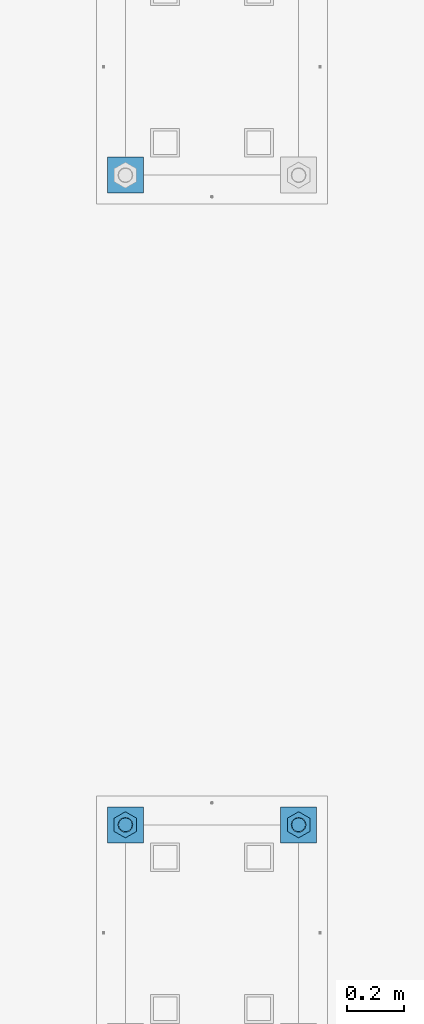
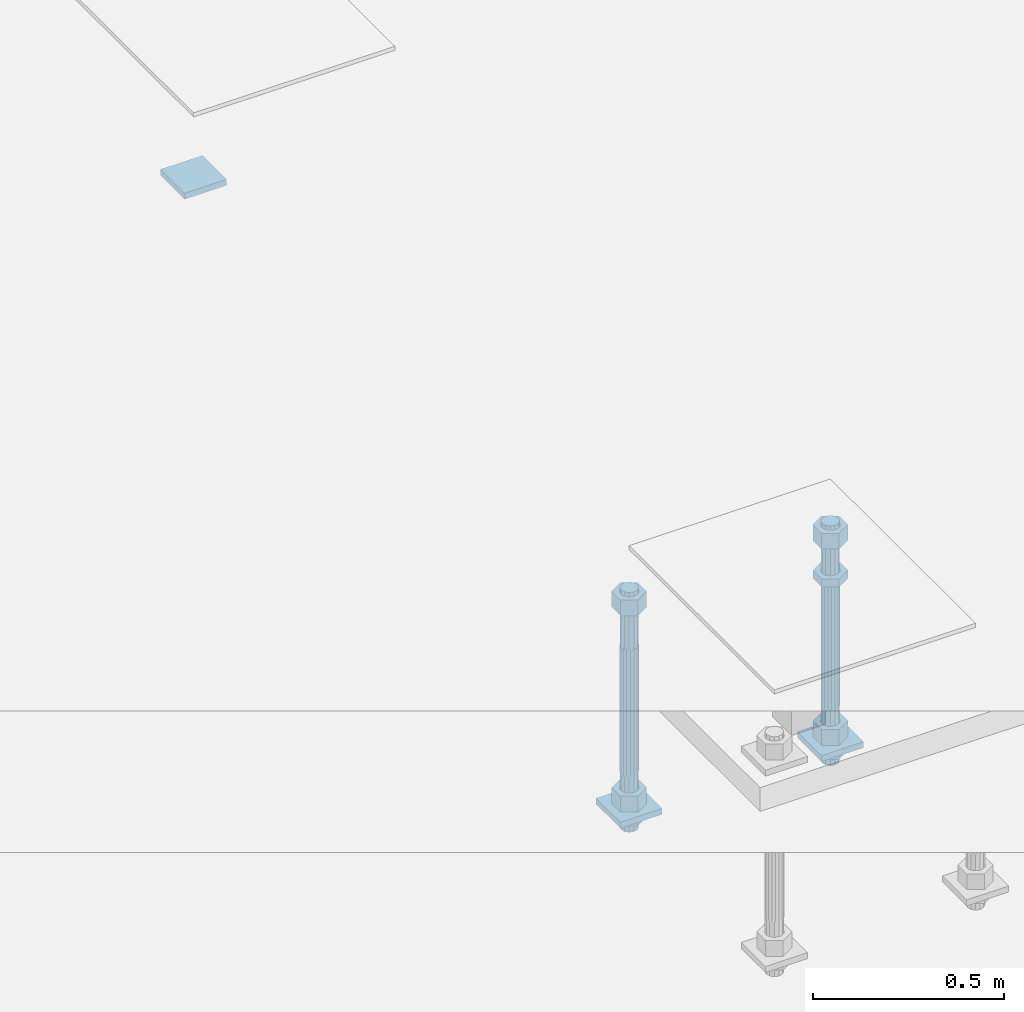
# One storey, part 2641 of 3843: 12 beams, 2 elements without a shape of their own.
"""IFC2X3 building model written with IfcOpenShell, lengths in millimetres."""

from ifc_helpers import new_model, si_unit, frame, origin_with_axes, place, context, subcontext, project, spatial, faceted_brep, material, type_object, element, aggregate, save


model = new_model("IFC2X3")

# Units and contexts
model_context = context("Model", 3, precision=1e-05, world=origin_with_axes())
body_context = subcontext(model_context, "Body", "Model", "MODEL_VIEW")
ifc_project = project(units=[si_unit("LENGTHUNIT", "METRE", prefix="MILLI"), si_unit("AREAUNIT", "SQUARE_METRE"), si_unit("VOLUMEUNIT", "CUBIC_METRE"), si_unit("MASSUNIT", "GRAM", prefix="KILO"), si_unit("TIMEUNIT", "SECOND"), si_unit("PLANEANGLEUNIT", "RADIAN"), si_unit("SOLIDANGLEUNIT", "STERADIAN"), si_unit("THERMODYNAMICTEMPERATUREUNIT", "DEGREE_CELSIUS"), si_unit("LUMINOUSINTENSITYUNIT", "LUMEN")], contexts=[model_context])

# Site, building, storey
site_placement = place(None, origin_with_axes())
site = spatial("IfcSite", under=ifc_project, at=site_placement, CompositionType="ELEMENT")
building_placement = place(site_placement, origin_with_axes())
building = spatial("IfcBuilding", under=site, at=building_placement, Name="Undefined", CompositionType="ELEMENT")
storey_placement = place(building_placement, origin_with_axes())
storey = spatial("IfcBuildingStorey", under=building, at=storey_placement, Name="Undefined", CompositionType="ELEMENT", Elevation=0.0)

# Assembly, beam
assembly_1_placement = place(storey_placement, origin_with_axes())
assembly_1 = element("IfcElementAssembly", 1, at=assembly_1_placement, inside=storey, Name="TEMPLATE", AssemblyPlace="NOTDEFINED", PredefinedType="RIGID_FRAME")
ifc_material_1 = material(Name="STEEL/A36")
beam_type_1 = type_object("IfcBeamType", PredefinedType="NOTDEFINED")
beam_1_placement = place(assembly_1_placement, frame((115862.099998474, 10121.9, 29873.575), z_axis=(0.0, 1.0, 0.0), x_axis=(-1.0, 0.0, 0.0)))
beam_1 = element("IfcBeam", 2, at=beam_1_placement, type_object=beam_type_1, material=ifc_material_1, Name="WASHER_PLATE", context=body_context, shape_type="Brep", body=[
    faceted_brep([(0.0, 9.52500000000146, -63.5), (0.0, 9.52500000000146, 63.5), (127.0, 9.52500000000146, 63.5), (127.0, 9.52500000000146, -63.5), (0.0, -9.52500000000146, 63.5), (127.0, -9.52500000000146, 63.5), (0.0, -9.52500000000146, -63.5), (127.0, -9.52500000000146, -63.5)], [[[0, 1, 2, 3]], [[1, 4, 5, 2]], [[4, 6, 7, 5]], [[6, 0, 3, 7]], [[5, 7, 3, 2]], [[6, 4, 1, 0]]]),
])
aggregate(assembly_1, [beam_1])

# Assembly, beams
assembly_2_placement = place(storey_placement, origin_with_axes())
assembly_2 = element("IfcElementAssembly", 3, at=assembly_2_placement, inside=storey, Name="TEMPLATE", AssemblyPlace="NOTDEFINED", PredefinedType="RIGID_FRAME")
beam_2_placement = place(assembly_2_placement, frame((116471.7, 7835.90000000001, 29244.925), z_axis=(0.0, 1.0, 0.0), x_axis=(-1.0, 0.0, 0.0)))
beam_2 = element("IfcBeam", 4, at=beam_2_placement, type_object=beam_type_1, material=ifc_material_1, Name="WASHER_PLATE", context=body_context, shape_type="Brep", body=[
    faceted_brep([(0.0, 9.52500000000146, -63.5), (0.0, 9.52500000000146, 63.5), (127.0, 9.52500000000146, 63.5), (127.0, 9.52500000000146, -63.5), (0.0, -9.52500000000146, 63.5), (127.0, -9.52500000000146, 63.5), (0.0, -9.52500000000146, -63.5), (127.0, -9.52500000000146, -63.5)], [[[0, 1, 2, 3]], [[1, 4, 5, 2]], [[4, 6, 7, 5]], [[6, 0, 3, 7]], [[5, 7, 3, 2]], [[6, 4, 1, 0]]]),
])
beam_3_placement = place(assembly_2_placement, frame((115862.099998474, 7835.90000000001, 29244.925), z_axis=(0.0, 1.0, 0.0), x_axis=(-1.0, 0.0, 0.0)))
beam_3 = element("IfcBeam", 5, at=beam_3_placement, type_object=beam_type_1, material=ifc_material_1, Name="WASHER_PLATE", context=body_context, shape_type="Brep", body=[
    faceted_brep([(0.0, 9.52500000000146, -63.5), (0.0, 9.52500000000146, 63.5), (127.0, 9.52500000000146, 63.5), (127.0, 9.52500000000146, -63.5), (0.0, -9.52500000000146, 63.5), (127.0, -9.52500000000146, 63.5), (0.0, -9.52500000000146, -63.5), (127.0, -9.52500000000146, -63.5)], [[[0, 1, 2, 3]], [[1, 4, 5, 2]], [[4, 6, 7, 5]], [[6, 0, 3, 7]], [[5, 7, 3, 2]], [[6, 4, 1, 0]]]),
])
beam_type_2 = type_object("IfcBeamType", Name="2_HALF_NUT", PredefinedType="NOTDEFINED")
beam_4_placement = place(assembly_2_placement, frame((115798.599998474, 7835.9, 29235.4), z_axis=(-1.0, 0.0, 0.0), x_axis=(0.0, 0.0, -1.0)))
beam_4 = element("IfcBeam", 6, at=beam_4_placement, type_object=beam_type_2, material=ifc_material_1, Name="NUT", ObjectType="2_HALF_NUT", context=body_context, shape_type="Brep", body=[
    faceted_brep([(0.0, -46.0369987487793, 0.0), (0.0, -23.0184993743896, -39.869213104248), (25.4000000000015, -23.0184993743896, -39.869213104248), (25.4000000000015, -46.0369987487793, 0.0), (0.0, 23.0184993743896, -39.869213104248), (25.4000000000015, 23.0184993743896, -39.869213104248), (0.0, 46.0369987487793, 0.0), (25.4000000000015, 46.0369987487793, 0.0), (0.0, 23.0184993743896, 39.869213104248), (25.4000000000015, 23.0184993743896, 39.869213104248), (0.0, -23.0184993743896, 39.869213104248), (25.4000000000015, -23.0184993743896, 39.869213104248), (0.0, 0.0, 26.1940002441406), (0.0, 11.3650617044477, 23.5999013092805), (25.4000000000015, 11.3650617044477, 23.5999013092805), (25.4000000000015, 0.0, 26.1940002441406), (0.0, 20.4791109456419, 16.3316083006721), (25.4000000000015, 20.4791109456419, 16.3316083006721), (0.0, 25.5370200498292, 5.82867859874386), (25.4000000000015, 25.5370200498292, 5.82867859874386), (0.0, 25.5370200498292, -5.82867859874386), (25.4000000000015, 25.5370200498292, -5.82867859874386), (0.0, 20.4791109456419, -16.3316083006721), (25.4000000000015, 20.4791109456419, -16.3316083006721), (0.0, 11.3650617044477, -23.5999013092805), (25.4000000000015, 11.3650617044477, -23.5999013092805), (0.0, 0.0, -26.1940002441406), (25.4000000000015, 0.0, -26.1940002441406), (0.0, -11.3650617044477, -23.5999013092805), (25.4000000000015, -11.3650617044477, -23.5999013092805), (0.0, -20.4791109456419, -16.3316083006721), (25.4000000000015, -20.4791109456419, -16.3316083006721), (0.0, -25.5370200498292, -5.82867859874386), (25.4000000000015, -25.5370200498292, -5.82867859874386), (0.0, -25.5370200498292, 5.82867859874386), (25.4000000000015, -25.5370200498292, 5.82867859874386), (0.0, -20.4791109456419, 16.3316083006721), (25.4000000000015, -20.4791109456419, 16.3316083006721), (0.0, -11.3650617044477, 23.5999013092805), (25.4000000000015, -11.3650617044477, 23.5999013092805)], [[[0, 1, 2, 3]], [[1, 4, 5, 2]], [[4, 6, 7, 5]], [[6, 8, 9, 7]], [[8, 10, 11, 9]], [[10, 0, 3, 11]], [[12, 13, 14, 15]], [[13, 16, 17, 14]], [[16, 18, 19, 17]], [[18, 20, 21, 19]], [[20, 22, 23, 21]], [[22, 24, 25, 23]], [[24, 26, 27, 25]], [[26, 28, 29, 27]], [[28, 30, 31, 29]], [[30, 32, 33, 31]], [[32, 34, 35, 33]], [[34, 36, 37, 35]], [[36, 38, 39, 37]], [[38, 12, 15, 39]], [[5, 7, 9, 11, 3, 2], [17, 19, 21, 23, 25, 27, 29, 31, 33, 35, 37, 39, 15, 14]], [[10, 8, 6, 4, 1, 0], [38, 36, 34, 32, 30, 28, 26, 24, 22, 20, 18, 16, 13, 12]]]),
])
beam_5_placement = place(assembly_2_placement, frame((116408.2, 7835.90000000001, 29787.85), z_axis=(-1.0, 0.0, 0.0), x_axis=(0.0, 0.0, -1.0)))
beam_5 = element("IfcBeam", 7, at=beam_5_placement, type_object=beam_type_2, material=ifc_material_1, Name="NUT", ObjectType="2_HALF_NUT", context=body_context, shape_type="Brep", body=[
    faceted_brep([(0.0, -46.0369987487793, 0.0), (0.0, -23.0184993743896, -39.869213104248), (25.4000000000015, -23.0184993743896, -39.869213104248), (25.4000000000015, -46.0369987487793, 0.0), (0.0, 23.0184993743896, -39.869213104248), (25.4000000000015, 23.0184993743896, -39.869213104248), (0.0, 46.0369987487793, 0.0), (25.4000000000015, 46.0369987487793, 0.0), (0.0, 23.0184993743896, 39.869213104248), (25.4000000000015, 23.0184993743896, 39.869213104248), (0.0, -23.0184993743896, 39.869213104248), (25.4000000000015, -23.0184993743896, 39.869213104248), (0.0, 0.0, 26.1940002441406), (0.0, 11.3650617044477, 23.5999013092805), (25.4000000000015, 11.3650617044477, 23.5999013092805), (25.4000000000015, 0.0, 26.1940002441406), (0.0, 20.4791109456419, 16.3316083006721), (25.4000000000015, 20.4791109456419, 16.3316083006721), (0.0, 25.5370200498292, 5.82867859874386), (25.4000000000015, 25.5370200498292, 5.82867859874386), (0.0, 25.5370200498292, -5.82867859874386), (25.4000000000015, 25.5370200498292, -5.82867859874386), (0.0, 20.4791109456419, -16.3316083006721), (25.4000000000015, 20.4791109456419, -16.3316083006721), (0.0, 11.3650617044477, -23.5999013092805), (25.4000000000015, 11.3650617044477, -23.5999013092805), (0.0, 0.0, -26.1940002441406), (25.4000000000015, 0.0, -26.1940002441406), (0.0, -11.3650617044477, -23.5999013092805), (25.4000000000015, -11.3650617044477, -23.5999013092805), (0.0, -20.4791109456419, -16.3316083006721), (25.4000000000015, -20.4791109456419, -16.3316083006721), (0.0, -25.5370200498292, -5.82867859874386), (25.4000000000015, -25.5370200498292, -5.82867859874386), (0.0, -25.5370200498292, 5.82867859874386), (25.4000000000015, -25.5370200498292, 5.82867859874386), (0.0, -20.4791109456419, 16.3316083006721), (25.4000000000015, -20.4791109456419, 16.3316083006721), (0.0, -11.3650617044477, 23.5999013092805), (25.4000000000015, -11.3650617044477, 23.5999013092805)], [[[0, 1, 2, 3]], [[1, 4, 5, 2]], [[4, 6, 7, 5]], [[6, 8, 9, 7]], [[8, 10, 11, 9]], [[10, 0, 3, 11]], [[12, 13, 14, 15]], [[13, 16, 17, 14]], [[16, 18, 19, 17]], [[18, 20, 21, 19]], [[20, 22, 23, 21]], [[22, 24, 25, 23]], [[24, 26, 27, 25]], [[26, 28, 29, 27]], [[28, 30, 31, 29]], [[30, 32, 33, 31]], [[32, 34, 35, 33]], [[34, 36, 37, 35]], [[36, 38, 39, 37]], [[38, 12, 15, 39]], [[5, 7, 9, 11, 3, 2], [17, 19, 21, 23, 25, 27, 29, 31, 33, 35, 37, 39, 15, 14]], [[10, 8, 6, 4, 1, 0], [38, 36, 34, 32, 30, 28, 26, 24, 22, 20, 18, 16, 13, 12]]]),
])
beam_6_placement = place(assembly_2_placement, frame((116408.2, 7835.9, 29235.4), z_axis=(-1.0, 0.0, 0.0), x_axis=(0.0, 0.0, -1.0)))
beam_6 = element("IfcBeam", 8, at=beam_6_placement, type_object=beam_type_2, material=ifc_material_1, Name="NUT", ObjectType="2_HALF_NUT", context=body_context, shape_type="Brep", body=[
    faceted_brep([(0.0, -46.0369987487793, 0.0), (0.0, -23.0184993743896, -39.869213104248), (25.4000000000015, -23.0184993743896, -39.869213104248), (25.4000000000015, -46.0369987487793, 0.0), (0.0, 23.0184993743896, -39.869213104248), (25.4000000000015, 23.0184993743896, -39.869213104248), (0.0, 46.0369987487793, 0.0), (25.4000000000015, 46.0369987487793, 0.0), (0.0, 23.0184993743896, 39.869213104248), (25.4000000000015, 23.0184993743896, 39.869213104248), (0.0, -23.0184993743896, 39.869213104248), (25.4000000000015, -23.0184993743896, 39.869213104248), (0.0, 0.0, 26.1940002441406), (0.0, 11.3650617044477, 23.5999013092805), (25.4000000000015, 11.3650617044477, 23.5999013092805), (25.4000000000015, 0.0, 26.1940002441406), (0.0, 20.4791109456419, 16.3316083006721), (25.4000000000015, 20.4791109456419, 16.3316083006721), (0.0, 25.5370200498292, 5.82867859874386), (25.4000000000015, 25.5370200498292, 5.82867859874386), (0.0, 25.5370200498292, -5.82867859874386), (25.4000000000015, 25.5370200498292, -5.82867859874386), (0.0, 20.4791109456419, -16.3316083006721), (25.4000000000015, 20.4791109456419, -16.3316083006721), (0.0, 11.3650617044477, -23.5999013092805), (25.4000000000015, 11.3650617044477, -23.5999013092805), (0.0, 0.0, -26.1940002441406), (25.4000000000015, 0.0, -26.1940002441406), (0.0, -11.3650617044477, -23.5999013092805), (25.4000000000015, -11.3650617044477, -23.5999013092805), (0.0, -20.4791109456419, -16.3316083006721), (25.4000000000015, -20.4791109456419, -16.3316083006721), (0.0, -25.5370200498292, -5.82867859874386), (25.4000000000015, -25.5370200498292, -5.82867859874386), (0.0, -25.5370200498292, 5.82867859874386), (25.4000000000015, -25.5370200498292, 5.82867859874386), (0.0, -20.4791109456419, 16.3316083006721), (25.4000000000015, -20.4791109456419, 16.3316083006721), (0.0, -11.3650617044477, 23.5999013092805), (25.4000000000015, -11.3650617044477, 23.5999013092805)], [[[0, 1, 2, 3]], [[1, 4, 5, 2]], [[4, 6, 7, 5]], [[6, 8, 9, 7]], [[8, 10, 11, 9]], [[10, 0, 3, 11]], [[12, 13, 14, 15]], [[13, 16, 17, 14]], [[16, 18, 19, 17]], [[18, 20, 21, 19]], [[20, 22, 23, 21]], [[22, 24, 25, 23]], [[24, 26, 27, 25]], [[26, 28, 29, 27]], [[28, 30, 31, 29]], [[30, 32, 33, 31]], [[32, 34, 35, 33]], [[34, 36, 37, 35]], [[36, 38, 39, 37]], [[38, 12, 15, 39]], [[5, 7, 9, 11, 3, 2], [17, 19, 21, 23, 25, 27, 29, 31, 33, 35, 37, 39, 15, 14]], [[10, 8, 6, 4, 1, 0], [38, 36, 34, 32, 30, 28, 26, 24, 22, 20, 18, 16, 13, 12]]]),
])
beam_type_3 = type_object("IfcBeamType", Name="2_HEAVY_HEX_NUT", PredefinedType="NOTDEFINED")
beam_7_placement = place(assembly_2_placement, frame((115798.599998474, 7835.90000000001, 29933.9), z_axis=(-1.0, 0.0, 0.0), x_axis=(0.0, 0.0, -1.0)))
beam_7 = element("IfcBeam", 9, at=beam_7_placement, type_object=beam_type_3, material=ifc_material_1, Name="NUT", ObjectType="2_HEAVY_HEX_NUT", context=body_context, shape_type="Brep", body=[
    faceted_brep([(0.0, -46.0369987487793, 0.0), (0.0, -23.0184993743896, -39.869213104248), (50.7999999999993, -23.0184993743896, -39.869213104248), (50.7999999999993, -46.0369987487793, 0.0), (0.0, 23.0184993743896, -39.869213104248), (50.7999999999993, 23.0184993743896, -39.869213104248), (0.0, 46.0369987487793, 0.0), (50.7999999999993, 46.0369987487793, 0.0), (0.0, 23.0184993743896, 39.869213104248), (50.7999999999993, 23.0184993743896, 39.869213104248), (0.0, -23.0184993743896, 39.869213104248), (50.7999999999993, -23.0184993743896, 39.869213104248), (0.0, 0.0, 26.1940002441406), (0.0, 11.3650617044477, 23.5999013092805), (50.7999999999993, 11.3650617044477, 23.5999013092805), (50.7999999999993, 0.0, 26.1940002441406), (0.0, 20.4791109456419, 16.3316083006721), (50.7999999999993, 20.4791109456419, 16.3316083006721), (0.0, 25.5370200498292, 5.82867859874386), (50.7999999999993, 25.5370200498292, 5.82867859874386), (0.0, 25.5370200498292, -5.82867859874386), (50.7999999999993, 25.5370200498292, -5.82867859874386), (0.0, 20.4791109456419, -16.3316083006721), (50.7999999999993, 20.4791109456419, -16.3316083006721), (0.0, 11.3650617044477, -23.5999013092805), (50.7999999999993, 11.3650617044477, -23.5999013092805), (0.0, 0.0, -26.1940002441406), (50.7999999999993, 0.0, -26.1940002441406), (0.0, -11.3650617044477, -23.5999013092805), (50.7999999999993, -11.3650617044477, -23.5999013092805), (0.0, -20.4791109456419, -16.3316083006721), (50.7999999999993, -20.4791109456419, -16.3316083006721), (0.0, -25.5370200498292, -5.82867859874386), (50.7999999999993, -25.5370200498292, -5.82867859874386), (0.0, -25.5370200498292, 5.82867859874386), (50.7999999999993, -25.5370200498292, 5.82867859874386), (0.0, -20.4791109456419, 16.3316083006721), (50.7999999999993, -20.4791109456419, 16.3316083006721), (0.0, -11.3650617044477, 23.5999013092805), (50.7999999999993, -11.3650617044477, 23.5999013092805)], [[[0, 1, 2, 3]], [[1, 4, 5, 2]], [[4, 6, 7, 5]], [[6, 8, 9, 7]], [[8, 10, 11, 9]], [[10, 0, 3, 11]], [[12, 13, 14, 15]], [[13, 16, 17, 14]], [[16, 18, 19, 17]], [[18, 20, 21, 19]], [[20, 22, 23, 21]], [[22, 24, 25, 23]], [[24, 26, 27, 25]], [[26, 28, 29, 27]], [[28, 30, 31, 29]], [[30, 32, 33, 31]], [[32, 34, 35, 33]], [[34, 36, 37, 35]], [[36, 38, 39, 37]], [[38, 12, 15, 39]], [[5, 7, 9, 11, 3, 2], [17, 19, 21, 23, 25, 27, 29, 31, 33, 35, 37, 39, 15, 14]], [[10, 8, 6, 4, 1, 0], [38, 36, 34, 32, 30, 28, 26, 24, 22, 20, 18, 16, 13, 12]]]),
])
beam_8_placement = place(assembly_2_placement, frame((115798.599998474, 7835.90000000001, 29305.25), z_axis=(-1.0, 0.0, 0.0), x_axis=(0.0, 0.0, -1.0)))
beam_8 = element("IfcBeam", 10, at=beam_8_placement, type_object=beam_type_3, material=ifc_material_1, Name="NUT", ObjectType="2_HEAVY_HEX_NUT", context=body_context, shape_type="Brep", body=[
    faceted_brep([(0.0, -46.0369987487793, 0.0), (0.0, -23.0184993743896, -39.869213104248), (50.7999999999993, -23.0184993743896, -39.869213104248), (50.7999999999993, -46.0369987487793, 0.0), (0.0, 23.0184993743896, -39.869213104248), (50.7999999999993, 23.0184993743896, -39.869213104248), (0.0, 46.0369987487793, 0.0), (50.7999999999993, 46.0369987487793, 0.0), (0.0, 23.0184993743896, 39.869213104248), (50.7999999999993, 23.0184993743896, 39.869213104248), (0.0, -23.0184993743896, 39.869213104248), (50.7999999999993, -23.0184993743896, 39.869213104248), (0.0, 0.0, 26.1940002441406), (0.0, 11.3650617044477, 23.5999013092805), (50.7999999999993, 11.3650617044477, 23.5999013092805), (50.7999999999993, 0.0, 26.1940002441406), (0.0, 20.4791109456419, 16.3316083006721), (50.7999999999993, 20.4791109456419, 16.3316083006721), (0.0, 25.5370200498292, 5.82867859874386), (50.7999999999993, 25.5370200498292, 5.82867859874386), (0.0, 25.5370200498292, -5.82867859874386), (50.7999999999993, 25.5370200498292, -5.82867859874386), (0.0, 20.4791109456419, -16.3316083006721), (50.7999999999993, 20.4791109456419, -16.3316083006721), (0.0, 11.3650617044477, -23.5999013092805), (50.7999999999993, 11.3650617044477, -23.5999013092805), (0.0, 0.0, -26.1940002441406), (50.7999999999993, 0.0, -26.1940002441406), (0.0, -11.3650617044477, -23.5999013092805), (50.7999999999993, -11.3650617044477, -23.5999013092805), (0.0, -20.4791109456419, -16.3316083006721), (50.7999999999993, -20.4791109456419, -16.3316083006721), (0.0, -25.5370200498292, -5.82867859874386), (50.7999999999993, -25.5370200498292, -5.82867859874386), (0.0, -25.5370200498292, 5.82867859874386), (50.7999999999993, -25.5370200498292, 5.82867859874386), (0.0, -20.4791109456419, 16.3316083006721), (50.7999999999993, -20.4791109456419, 16.3316083006721), (0.0, -11.3650617044477, 23.5999013092805), (50.7999999999993, -11.3650617044477, 23.5999013092805)], [[[0, 1, 2, 3]], [[1, 4, 5, 2]], [[4, 6, 7, 5]], [[6, 8, 9, 7]], [[8, 10, 11, 9]], [[10, 0, 3, 11]], [[12, 13, 14, 15]], [[13, 16, 17, 14]], [[16, 18, 19, 17]], [[18, 20, 21, 19]], [[20, 22, 23, 21]], [[22, 24, 25, 23]], [[24, 26, 27, 25]], [[26, 28, 29, 27]], [[28, 30, 31, 29]], [[30, 32, 33, 31]], [[32, 34, 35, 33]], [[34, 36, 37, 35]], [[36, 38, 39, 37]], [[38, 12, 15, 39]], [[5, 7, 9, 11, 3, 2], [17, 19, 21, 23, 25, 27, 29, 31, 33, 35, 37, 39, 15, 14]], [[10, 8, 6, 4, 1, 0], [38, 36, 34, 32, 30, 28, 26, 24, 22, 20, 18, 16, 13, 12]]]),
])
beam_9_placement = place(assembly_2_placement, frame((116408.2, 7835.90000000001, 29933.9), z_axis=(-1.0, 0.0, 0.0), x_axis=(0.0, 0.0, -1.0)))
beam_9 = element("IfcBeam", 11, at=beam_9_placement, type_object=beam_type_3, material=ifc_material_1, Name="NUT", ObjectType="2_HEAVY_HEX_NUT", context=body_context, shape_type="Brep", body=[
    faceted_brep([(0.0, -46.0369987487793, 0.0), (0.0, -23.0184993743896, -39.869213104248), (50.7999999999993, -23.0184993743896, -39.869213104248), (50.7999999999993, -46.0369987487793, 0.0), (0.0, 23.0184993743896, -39.869213104248), (50.7999999999993, 23.0184993743896, -39.869213104248), (0.0, 46.0369987487793, 0.0), (50.7999999999993, 46.0369987487793, 0.0), (0.0, 23.0184993743896, 39.869213104248), (50.7999999999993, 23.0184993743896, 39.869213104248), (0.0, -23.0184993743896, 39.869213104248), (50.7999999999993, -23.0184993743896, 39.869213104248), (0.0, 0.0, 26.1940002441406), (0.0, 11.3650617044477, 23.5999013092805), (50.7999999999993, 11.3650617044477, 23.5999013092805), (50.7999999999993, 0.0, 26.1940002441406), (0.0, 20.4791109456419, 16.3316083006721), (50.7999999999993, 20.4791109456419, 16.3316083006721), (0.0, 25.5370200498292, 5.82867859874386), (50.7999999999993, 25.5370200498292, 5.82867859874386), (0.0, 25.5370200498292, -5.82867859874386), (50.7999999999993, 25.5370200498292, -5.82867859874386), (0.0, 20.4791109456419, -16.3316083006721), (50.7999999999993, 20.4791109456419, -16.3316083006721), (0.0, 11.3650617044477, -23.5999013092805), (50.7999999999993, 11.3650617044477, -23.5999013092805), (0.0, 0.0, -26.1940002441406), (50.7999999999993, 0.0, -26.1940002441406), (0.0, -11.3650617044477, -23.5999013092805), (50.7999999999993, -11.3650617044477, -23.5999013092805), (0.0, -20.4791109456419, -16.3316083006721), (50.7999999999993, -20.4791109456419, -16.3316083006721), (0.0, -25.5370200498292, -5.82867859874386), (50.7999999999993, -25.5370200498292, -5.82867859874386), (0.0, -25.5370200498292, 5.82867859874386), (50.7999999999993, -25.5370200498292, 5.82867859874386), (0.0, -20.4791109456419, 16.3316083006721), (50.7999999999993, -20.4791109456419, 16.3316083006721), (0.0, -11.3650617044477, 23.5999013092805), (50.7999999999993, -11.3650617044477, 23.5999013092805)], [[[0, 1, 2, 3]], [[1, 4, 5, 2]], [[4, 6, 7, 5]], [[6, 8, 9, 7]], [[8, 10, 11, 9]], [[10, 0, 3, 11]], [[12, 13, 14, 15]], [[13, 16, 17, 14]], [[16, 18, 19, 17]], [[18, 20, 21, 19]], [[20, 22, 23, 21]], [[22, 24, 25, 23]], [[24, 26, 27, 25]], [[26, 28, 29, 27]], [[28, 30, 31, 29]], [[30, 32, 33, 31]], [[32, 34, 35, 33]], [[34, 36, 37, 35]], [[36, 38, 39, 37]], [[38, 12, 15, 39]], [[5, 7, 9, 11, 3, 2], [17, 19, 21, 23, 25, 27, 29, 31, 33, 35, 37, 39, 15, 14]], [[10, 8, 6, 4, 1, 0], [38, 36, 34, 32, 30, 28, 26, 24, 22, 20, 18, 16, 13, 12]]]),
])
beam_10_placement = place(assembly_2_placement, frame((116408.2, 7835.90000000001, 29305.25), z_axis=(-1.0, 0.0, 0.0), x_axis=(0.0, 0.0, -1.0)))
beam_10 = element("IfcBeam", 12, at=beam_10_placement, type_object=beam_type_3, material=ifc_material_1, Name="NUT", ObjectType="2_HEAVY_HEX_NUT", context=body_context, shape_type="Brep", body=[
    faceted_brep([(0.0, -46.0369987487793, 0.0), (0.0, -23.0184993743896, -39.869213104248), (50.7999999999993, -23.0184993743896, -39.869213104248), (50.7999999999993, -46.0369987487793, 0.0), (0.0, 23.0184993743896, -39.869213104248), (50.7999999999993, 23.0184993743896, -39.869213104248), (0.0, 46.0369987487793, 0.0), (50.7999999999993, 46.0369987487793, 0.0), (0.0, 23.0184993743896, 39.869213104248), (50.7999999999993, 23.0184993743896, 39.869213104248), (0.0, -23.0184993743896, 39.869213104248), (50.7999999999993, -23.0184993743896, 39.869213104248), (0.0, 0.0, 26.1940002441406), (0.0, 11.3650617044477, 23.5999013092805), (50.7999999999993, 11.3650617044477, 23.5999013092805), (50.7999999999993, 0.0, 26.1940002441406), (0.0, 20.4791109456419, 16.3316083006721), (50.7999999999993, 20.4791109456419, 16.3316083006721), (0.0, 25.5370200498292, 5.82867859874386), (50.7999999999993, 25.5370200498292, 5.82867859874386), (0.0, 25.5370200498292, -5.82867859874386), (50.7999999999993, 25.5370200498292, -5.82867859874386), (0.0, 20.4791109456419, -16.3316083006721), (50.7999999999993, 20.4791109456419, -16.3316083006721), (0.0, 11.3650617044477, -23.5999013092805), (50.7999999999993, 11.3650617044477, -23.5999013092805), (0.0, 0.0, -26.1940002441406), (50.7999999999993, 0.0, -26.1940002441406), (0.0, -11.3650617044477, -23.5999013092805), (50.7999999999993, -11.3650617044477, -23.5999013092805), (0.0, -20.4791109456419, -16.3316083006721), (50.7999999999993, -20.4791109456419, -16.3316083006721), (0.0, -25.5370200498292, -5.82867859874386), (50.7999999999993, -25.5370200498292, -5.82867859874386), (0.0, -25.5370200498292, 5.82867859874386), (50.7999999999993, -25.5370200498292, 5.82867859874386), (0.0, -20.4791109456419, 16.3316083006721), (50.7999999999993, -20.4791109456419, 16.3316083006721), (0.0, -11.3650617044477, 23.5999013092805), (50.7999999999993, -11.3650617044477, 23.5999013092805)], [[[0, 1, 2, 3]], [[1, 4, 5, 2]], [[4, 6, 7, 5]], [[6, 8, 9, 7]], [[8, 10, 11, 9]], [[10, 0, 3, 11]], [[12, 13, 14, 15]], [[13, 16, 17, 14]], [[16, 18, 19, 17]], [[18, 20, 21, 19]], [[20, 22, 23, 21]], [[22, 24, 25, 23]], [[24, 26, 27, 25]], [[26, 28, 29, 27]], [[28, 30, 31, 29]], [[30, 32, 33, 31]], [[32, 34, 35, 33]], [[34, 36, 37, 35]], [[36, 38, 39, 37]], [[38, 12, 15, 39]], [[5, 7, 9, 11, 3, 2], [17, 19, 21, 23, 25, 27, 29, 31, 33, 35, 37, 39, 15, 14]], [[10, 8, 6, 4, 1, 0], [38, 36, 34, 32, 30, 28, 26, 24, 22, 20, 18, 16, 13, 12]]]),
])
ifc_material_2 = material()
beam_type_4 = type_object("IfcBeamType", PredefinedType="NOTDEFINED")
beam_11_placement = place(assembly_2_placement, frame((115798.599998474, 7835.90000000001, 29762.45), z_axis=(-1.0, 0.0, 0.0), x_axis=(0.0, 0.0, -1.0)))
beam_11 = element("IfcBeam", 13, at=beam_11_placement, type_object=beam_type_4, material=ifc_material_2, Name="ANCHOR_ROD", context=body_context, shape_type="Brep", body=[
    faceted_brep([(-184.150000000001, -21.217622392709, 12.25), (-184.150000000001, -12.2499999999854, 21.2176223927163), (-184.150000000001, 1.45519152283669e-11, 24.5), (-184.150000000001, 12.2500000000146, 21.2176223927163), (-184.150000000001, 21.2176223927381, 12.25), (-184.150000000001, 24.5000000000146, 0.0), (-184.150000000001, 21.2176223927381, -12.25), (-184.150000000001, 12.2500000000146, -21.2176223927163), (-184.150000000001, 1.45519152283669e-11, -24.5), (-184.150000000001, -12.2499999999854, -21.2176223927163), (-184.150000000001, -21.217622392709, -12.25), (-184.150000000001, -24.4999999999854, 0.0), (0.0, 24.5000000000146, 0.0), (0.0, 21.2176223927381, -12.25), (0.0, 12.2500000000146, -21.2176223927163), (0.0, 1.45519152283669e-11, -24.5), (0.0, -12.2499999999854, -21.2176223927163), (0.0, -21.217622392709, -12.25), (0.0, -24.4999999999854, 0.0), (0.0, -21.217622392709, 12.25), (0.0, -12.2499999999854, 21.2176223927163), (0.0, 1.45519152283669e-11, 24.5), (0.0, 12.2500000000146, 21.2176223927163), (0.0, 21.2176223927381, 12.25), (0.0, -23.4665401257807, 9.72015918207035), (0.0, -17.9605122421344, 17.9605122421417), (0.0, -9.72015918207762, 23.466540125788), (0.0, 0.0, 25.4000000000015), (0.0, 9.72015918207762, 23.466540125788), (0.0, 17.9605122421344, 17.9605122421417), (0.0, 23.4665401257807, 9.72015918207035), (0.0, 25.3999996185303, 0.0), (0.0, 23.4665401257807, -9.72015918207035), (0.0, 17.9605122421344, -17.9605122421417), (0.0, 9.72015918207762, -23.466540125788), (0.0, 0.0, -25.4000000000015), (0.0, -9.72015918207762, -23.466540125788), (0.0, -17.9605122421344, -17.9605122421417), (0.0, -23.4665401257807, -9.72015918207035), (0.0, -25.3999996185303, 0.0), (406.399999999998, -25.3999999999942, 0.0), (406.399999999998, -23.4665401257807, 9.72015918207035), (406.399999999998, -17.9605122421344, 17.9605122421417), (406.399999999998, -9.72015918207762, 23.466540125788), (406.399999999998, 0.0, 25.4000000000015), (406.399999999998, 9.72015918207762, 23.466540125788), (406.399999999998, 17.9605122421344, 17.9605122421417), (406.399999999998, 23.4665401257807, 9.72015918207035), (406.399999999998, 25.3999999999942, 0.0), (406.399999999998, 23.4665401257807, -9.72015918207035), (406.399999999998, 17.9605122421344, -17.9605122421417), (406.399999999998, 9.72015918207762, -23.466540125788), (406.399999999998, 0.0, -25.4000000000015), (406.399999999998, -9.72015918207762, -23.466540125788), (406.399999999998, -17.9605122421344, -17.9605122421417), (406.399999999998, -23.4665401257807, -9.72015918207035), (406.399999999998, -12.2499999999854, 21.2176223927163), (406.399999999998, 1.45519152283669e-11, 24.5), (406.399999999998, 12.2500000000146, 21.2176223927163), (406.399999999998, 21.2176223927381, 12.25), (406.399999999998, 24.5000000000146, 0.0), (406.399999999998, 21.2176223927381, -12.25), (406.399999999998, 12.2500000000146, -21.2176223927163), (406.399999999998, 1.45519152283669e-11, -24.5), (406.399999999998, -12.2499999999854, -21.2176223927163), (406.399999999998, -21.217622392709, -12.25), (406.399999999998, -24.4999999999854, 0.0), (406.399999999998, -21.217622392709, 12.25), (584.200000000001, -12.2499999999854, -21.2176223927163), (584.200000000001, 1.45519152283669e-11, -24.5), (584.200000000001, 12.2500000000146, -21.2176223927163), (584.200000000001, 21.2176223927381, -12.25), (584.200000000001, 24.5000000000146, 0.0), (584.200000000001, 21.2176223927381, 12.25), (584.200000000001, 12.2500000000146, 21.2176223927163), (584.200000000001, 1.45519152283669e-11, 24.5), (584.200000000001, -12.2499999999854, 21.2176223927163), (584.200000000001, -21.217622392709, 12.25), (584.200000000001, -24.4999999999854, 0.0), (584.200000000001, -21.217622392709, -12.25)], [[[0, 1, 2, 3, 4, 5, 6, 7, 8, 9, 10, 11]], [[6, 5, 12, 13]], [[7, 6, 13, 14]], [[8, 7, 14, 15]], [[9, 8, 15, 16]], [[10, 9, 16, 17]], [[11, 10, 17, 18]], [[0, 11, 18, 19]], [[1, 0, 19, 20]], [[2, 1, 20, 21]], [[3, 2, 21, 22]], [[4, 3, 22, 23]], [[5, 4, 23, 12]], [[24, 25, 26, 27, 28, 29, 30, 31, 32, 33, 34, 35, 36, 37, 38, 39], [22, 21, 20, 19, 18, 17, 16, 15, 14, 13, 12, 23]], [[24, 39, 40, 41]], [[25, 24, 41, 42]], [[26, 25, 42, 43]], [[27, 26, 43, 44]], [[28, 27, 44, 45]], [[29, 28, 45, 46]], [[30, 29, 46, 47]], [[31, 30, 47, 48]], [[32, 31, 48, 49]], [[33, 32, 49, 50]], [[34, 33, 50, 51]], [[35, 34, 51, 52]], [[36, 35, 52, 53]], [[37, 36, 53, 54]], [[38, 37, 54, 55]], [[39, 38, 55, 40]], [[54, 53, 52, 51, 50, 49, 48, 47, 46, 45, 44, 43, 42, 41, 40, 55], [56, 57, 58, 59, 60, 61, 62, 63, 64, 65, 66, 67]], [[68, 69, 70, 71, 72, 73, 74, 75, 76, 77, 78, 79]], [[76, 75, 57, 56]], [[77, 76, 56, 67]], [[78, 77, 67, 66]], [[79, 78, 66, 65]], [[68, 79, 65, 64]], [[69, 68, 64, 63]], [[70, 69, 63, 62]], [[71, 70, 62, 61]], [[72, 71, 61, 60]], [[73, 72, 60, 59]], [[74, 73, 59, 58]], [[75, 74, 58, 57]]]),
])
beam_12_placement = place(assembly_2_placement, frame((116408.2, 7835.90000000001, 29762.45), z_axis=(-1.0, 0.0, 0.0), x_axis=(0.0, 0.0, -1.0)))
beam_12 = element("IfcBeam", 14, at=beam_12_placement, type_object=beam_type_4, material=ifc_material_2, Name="ANCHOR_ROD", context=body_context, shape_type="Brep", body=[
    faceted_brep([(-184.150000000001, -21.217622392709, 12.25), (-184.150000000001, -12.2499999999854, 21.2176223927163), (-184.150000000001, 1.45519152283669e-11, 24.5), (-184.150000000001, 12.2500000000146, 21.2176223927163), (-184.150000000001, 21.2176223927381, 12.25), (-184.150000000001, 24.5000000000146, 0.0), (-184.150000000001, 21.2176223927381, -12.25), (-184.150000000001, 12.2500000000146, -21.2176223927163), (-184.150000000001, 1.45519152283669e-11, -24.5), (-184.150000000001, -12.2499999999854, -21.2176223927163), (-184.150000000001, -21.217622392709, -12.25), (-184.150000000001, -24.4999999999854, 0.0), (0.0, 24.5000000000146, 0.0), (0.0, 21.2176223927381, -12.25), (0.0, 12.2500000000146, -21.2176223927163), (0.0, 1.45519152283669e-11, -24.5), (0.0, -12.2499999999854, -21.2176223927163), (0.0, -21.217622392709, -12.25), (0.0, -24.4999999999854, 0.0), (0.0, -21.217622392709, 12.25), (0.0, -12.2499999999854, 21.2176223927163), (0.0, 1.45519152283669e-11, 24.5), (0.0, 12.2500000000146, 21.2176223927163), (0.0, 21.2176223927381, 12.25), (0.0, -23.4665401257807, 9.72015918207035), (0.0, -17.9605122421344, 17.9605122421417), (0.0, -9.72015918207762, 23.466540125788), (0.0, 0.0, 25.4000000000015), (0.0, 9.72015918207762, 23.466540125788), (0.0, 17.9605122421344, 17.9605122421417), (0.0, 23.4665401257807, 9.72015918207035), (0.0, 25.3999996185303, 0.0), (0.0, 23.4665401257807, -9.72015918207035), (0.0, 17.9605122421344, -17.9605122421417), (0.0, 9.72015918207762, -23.466540125788), (0.0, 0.0, -25.4000000000015), (0.0, -9.72015918207762, -23.466540125788), (0.0, -17.9605122421344, -17.9605122421417), (0.0, -23.4665401257807, -9.72015918207035), (0.0, -25.3999996185303, 0.0), (406.399999999998, -25.3999999999942, 0.0), (406.399999999998, -23.4665401257807, 9.72015918207035), (406.399999999998, -17.9605122421344, 17.9605122421417), (406.399999999998, -9.72015918207762, 23.466540125788), (406.399999999998, 0.0, 25.4000000000015), (406.399999999998, 9.72015918207762, 23.466540125788), (406.399999999998, 17.9605122421344, 17.9605122421417), (406.399999999998, 23.4665401257807, 9.72015918207035), (406.399999999998, 25.3999999999942, 0.0), (406.399999999998, 23.4665401257807, -9.72015918207035), (406.399999999998, 17.9605122421344, -17.9605122421417), (406.399999999998, 9.72015918207762, -23.466540125788), (406.399999999998, 0.0, -25.4000000000015), (406.399999999998, -9.72015918207762, -23.466540125788), (406.399999999998, -17.9605122421344, -17.9605122421417), (406.399999999998, -23.4665401257807, -9.72015918207035), (406.399999999998, -12.2499999999854, 21.2176223927163), (406.399999999998, 1.45519152283669e-11, 24.5), (406.399999999998, 12.2500000000146, 21.2176223927163), (406.399999999998, 21.2176223927381, 12.25), (406.399999999998, 24.5000000000146, 0.0), (406.399999999998, 21.2176223927381, -12.25), (406.399999999998, 12.2500000000146, -21.2176223927163), (406.399999999998, 1.45519152283669e-11, -24.5), (406.399999999998, -12.2499999999854, -21.2176223927163), (406.399999999998, -21.217622392709, -12.25), (406.399999999998, -24.4999999999854, 0.0), (406.399999999998, -21.217622392709, 12.25), (584.200000000001, -12.2499999999854, -21.2176223927163), (584.200000000001, 1.45519152283669e-11, -24.5), (584.200000000001, 12.2500000000146, -21.2176223927163), (584.200000000001, 21.2176223927381, -12.25), (584.200000000001, 24.5000000000146, 0.0), (584.200000000001, 21.2176223927381, 12.25), (584.200000000001, 12.2500000000146, 21.2176223927163), (584.200000000001, 1.45519152283669e-11, 24.5), (584.200000000001, -12.2499999999854, 21.2176223927163), (584.200000000001, -21.217622392709, 12.25), (584.200000000001, -24.4999999999854, 0.0), (584.200000000001, -21.217622392709, -12.25)], [[[0, 1, 2, 3, 4, 5, 6, 7, 8, 9, 10, 11]], [[6, 5, 12, 13]], [[7, 6, 13, 14]], [[8, 7, 14, 15]], [[9, 8, 15, 16]], [[10, 9, 16, 17]], [[11, 10, 17, 18]], [[0, 11, 18, 19]], [[1, 0, 19, 20]], [[2, 1, 20, 21]], [[3, 2, 21, 22]], [[4, 3, 22, 23]], [[5, 4, 23, 12]], [[24, 25, 26, 27, 28, 29, 30, 31, 32, 33, 34, 35, 36, 37, 38, 39], [22, 21, 20, 19, 18, 17, 16, 15, 14, 13, 12, 23]], [[24, 39, 40, 41]], [[25, 24, 41, 42]], [[26, 25, 42, 43]], [[27, 26, 43, 44]], [[28, 27, 44, 45]], [[29, 28, 45, 46]], [[30, 29, 46, 47]], [[31, 30, 47, 48]], [[32, 31, 48, 49]], [[33, 32, 49, 50]], [[34, 33, 50, 51]], [[35, 34, 51, 52]], [[36, 35, 52, 53]], [[37, 36, 53, 54]], [[38, 37, 54, 55]], [[39, 38, 55, 40]], [[54, 53, 52, 51, 50, 49, 48, 47, 46, 45, 44, 43, 42, 41, 40, 55], [56, 57, 58, 59, 60, 61, 62, 63, 64, 65, 66, 67]], [[68, 69, 70, 71, 72, 73, 74, 75, 76, 77, 78, 79]], [[76, 75, 57, 56]], [[77, 76, 56, 67]], [[78, 77, 67, 66]], [[79, 78, 66, 65]], [[68, 79, 65, 64]], [[69, 68, 64, 63]], [[70, 69, 63, 62]], [[71, 70, 62, 61]], [[72, 71, 61, 60]], [[73, 72, 60, 59]], [[74, 73, 59, 58]], [[75, 74, 58, 57]]]),
])
aggregate(assembly_2, [beam_7, beam_8, beam_4, beam_11, beam_2, beam_5, beam_9, beam_10, beam_6, beam_12, beam_3])

save(model, "model.ifc")
